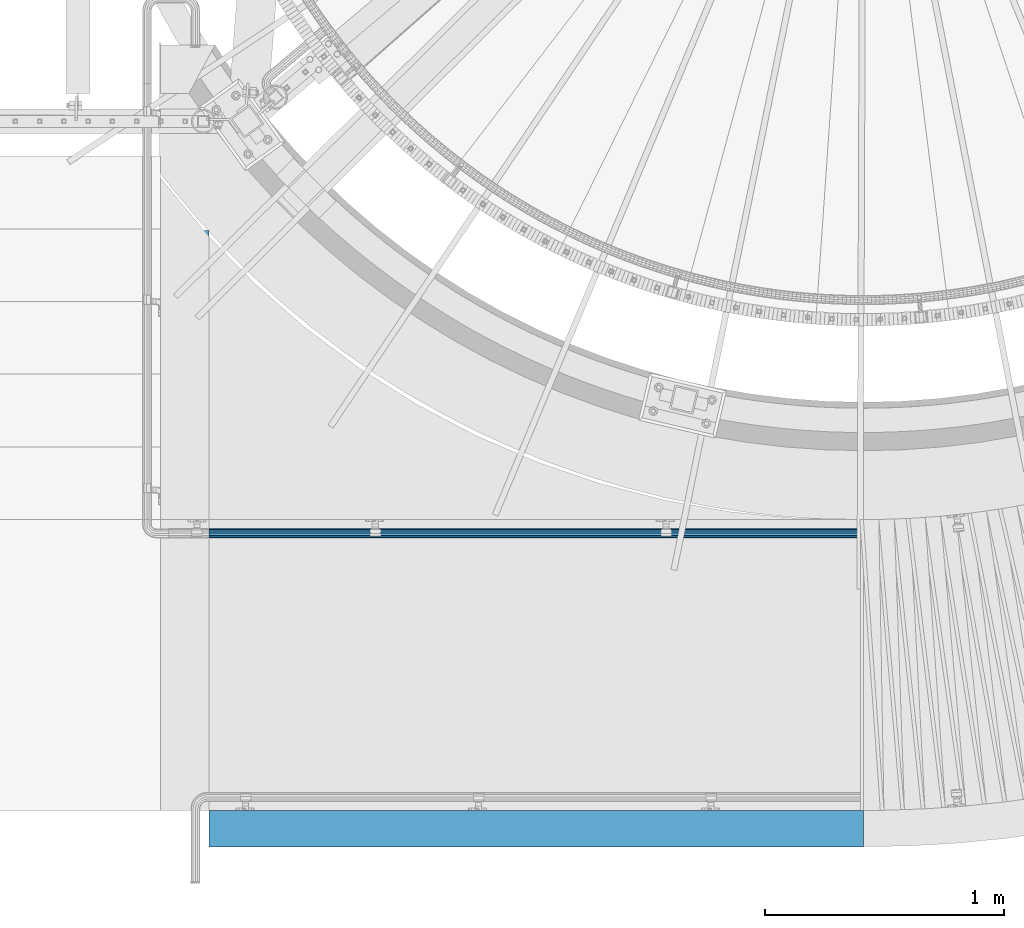
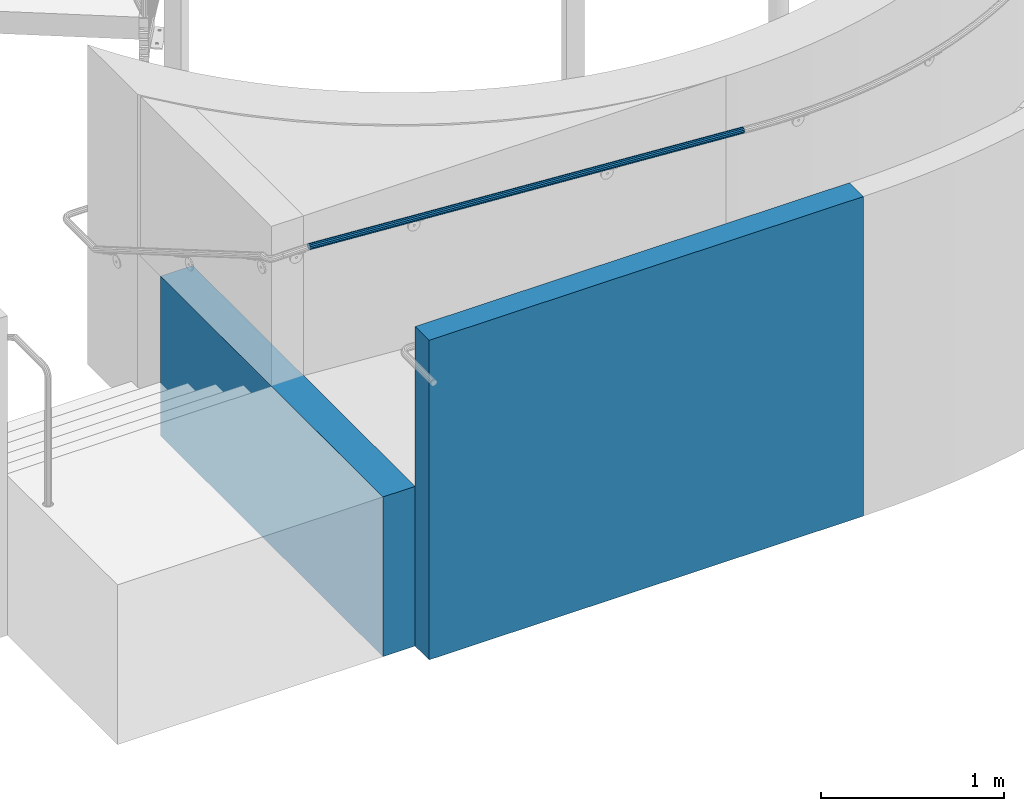
# One storey, part 335 of 975: 3 beams.
"""IFC2X3 building model written with IfcOpenShell, lengths in millimetres."""

from ifc_helpers import new_model, si_unit, frame, origin_with_axes, place, context, subcontext, project, spatial, faceted_brep, material, type_object, element, save


model = new_model("IFC2X3")

# Units and contexts
model_context = context("Model", 3, precision=1e-05, world=origin_with_axes())
body_context = subcontext(model_context, "Body", "Model", "MODEL_VIEW")
ifc_project = project(units=[si_unit("LENGTHUNIT", "METRE", prefix="MILLI"), si_unit("AREAUNIT", "SQUARE_METRE"), si_unit("VOLUMEUNIT", "CUBIC_METRE"), si_unit("MASSUNIT", "GRAM", prefix="KILO"), si_unit("TIMEUNIT", "SECOND"), si_unit("PLANEANGLEUNIT", "RADIAN"), si_unit("SOLIDANGLEUNIT", "STERADIAN"), si_unit("THERMODYNAMICTEMPERATUREUNIT", "DEGREE_CELSIUS"), si_unit("LUMINOUSINTENSITYUNIT", "LUMEN")], contexts=[model_context])

# Site, building, storey
site_placement = place(None, origin_with_axes())
site = spatial("IfcSite", under=ifc_project, at=site_placement, CompositionType="ELEMENT")
building_placement = place(site_placement, origin_with_axes())
building = spatial("IfcBuilding", under=site, at=building_placement, Name="Undefined", CompositionType="ELEMENT")
storey_placement = place(building_placement, origin_with_axes())
storey = spatial("IfcBuildingStorey", under=building, at=storey_placement, Name="Undefined", CompositionType="ELEMENT", Elevation=0.0)

# Beams
ifc_material_1 = material()
beam_type_1 = type_object("IfcBeamType", PredefinedType="NOTDEFINED")
beam_1_placement = place(storey_placement, frame((31990.0724565186, -361.949983764825, 1962.19143730185), z_axis=(0.06592640700025, 4.99999998737621e-09, 0.997824488003796), x_axis=(0.997824488003796, -1.97778945221216e-10, -0.0659264070002507)))
element("IfcBeam", 1, at=beam_1_placement, inside=storey, type_object=beam_type_1, material=ifc_material_1, Name="HANDRAIL", context=body_context, shape_type="Brep", body=[
    faceted_brep([(0.627401174744591, -15.3670000000001, 9.09494701772928e-13), (0.374349365571106, -13.3082123799555, 7.68350000000146), (2749.18278448434, -13.3082123799372, 7.68350000008013), (2749.18278448432, -15.3669999999818, 7.95807864051312e-11), (0.189102584990906, -7.68349999999992, 13.3082123799568), (2749.18278448434, -7.68349999998173, 13.3082123800355), (0.121297558256629, 1.13686837721616e-13, 15.3670000000006), (2749.18278448434, 1.8360424292041e-11, 15.3670000000793), (0.189102587526577, 7.68350000000009, 13.308212379955), (2749.18278448434, 7.68350000001828, 13.3082123800341), (0.374349369962147, 13.3082123799555, 7.68349999999828), (2749.18278448434, 13.3082123799738, 7.68350000007831), (0.627401179815934, 15.3670000000001, -1.81898940354586e-12), (2749.18278448433, 15.3670000000183, 7.68523022998124e-11), (0.88045298898578, 13.3082123799555, -7.68350000000191), (2749.18278448431, 13.3082123799737, -7.68349999992279), (1.06569976956598, 7.68350000000004, -13.3082123799572), (2749.1827844843, 7.68350000001817, -13.3082123798786), (1.1335047963039, 5.6843418860808e-14, -15.3670000000011), (2749.1827844843, 1.82467374543194e-11, -15.366999999922), (1.06569976703031, -7.68350000000004, -13.3082123799559), (2749.1827844843, -7.6834999999819, -13.3082123798777), (0.88045298459474, -13.3082123799555, -7.68349999999919), (2749.18278448431, -13.3082123799373, -7.68349999992097), (0.627401174137049, -19.05, 1.36424205265939e-12), (0.941101764859923, -16.4977839420936, -9.52499999999873), (2749.18278448431, -16.4977839420754, -9.52499999992096), (2749.18278450733, -19.0499979925621, 1.86693569048657e-07), (1.17074653647433, -9.52499999999998, -16.4977839420944), (2749.1827844843, -9.52499999998184, -16.4977839420144), (1.25480235788564, 0.0, -19.0500000000011), (2749.1827844843, 1.81898940354586e-11, -19.0499999999224), (1.17074653962118, 9.52500000000003, -16.4977839420962), (2749.1827844843, 9.52500000001822, -16.4977839420171), (0.941101770305977, 16.4977839420936, -9.52500000000191), (2749.18278448431, 16.4977839421118, -9.52499999992369), (0.627401180423476, 19.0500000000001, -1.81898940354586e-12), (2749.18278448432, 19.0500000000183, 7.6397554948926e-11), (0.313700589696964, 16.4977839420937, 9.52499999999873), (2749.18278448434, 16.4977839421119, 9.52500000007694), (0.084055818082561, 9.52500000000009, 16.4977839420931), (2749.18278448435, 9.52500000001834, 16.4977839421722), (-3.63797880709171e-12, 3.63797880709171e-12, 19.0500000000002), (2749.18278448435, 1.8360424292041e-11, 19.0500000000793), (0.0840558149393473, -9.52499999999998, 16.4977839420949), (2749.18278448435, -9.52499999998173, 16.4977839421736), (0.313700584254548, -16.4977839420936, 9.52500000000146), (2749.18278448434, -16.4977839420754, 9.52500000008058)], [[[0, 1, 2, 3]], [[1, 4, 5, 2]], [[4, 6, 7, 5]], [[6, 8, 9, 7]], [[8, 10, 11, 9]], [[10, 12, 13, 11]], [[12, 14, 15, 13]], [[14, 16, 17, 15]], [[16, 18, 19, 17]], [[18, 20, 21, 19]], [[20, 22, 23, 21]], [[22, 0, 3, 23]], [[24, 25, 26, 27]], [[25, 28, 29, 26]], [[28, 30, 31, 29]], [[30, 32, 33, 31]], [[32, 34, 35, 33]], [[34, 36, 37, 35]], [[36, 38, 39, 37]], [[38, 40, 41, 39]], [[40, 42, 43, 41]], [[42, 44, 45, 43]], [[44, 46, 47, 45]], [[46, 24, 27, 47]], [[29, 31, 33, 35, 37, 39, 41, 43, 45, 47, 27, 26], [5, 7, 9, 11, 13, 15, 17, 19, 21, 23, 3, 2]], [[46, 44, 42, 40, 38, 36, 34, 32, 30, 28, 25, 24], [22, 20, 18, 16, 14, 12, 10, 8, 6, 4, 1, 0]]]),
])
ifc_material_2 = material(Name="CONCRETE/5000")
beam_type_2 = type_object("IfcBeamType", PredefinedType="NOTDEFINED")
beam_2_placement = place(storey_placement, frame((31889.6999669118, 908.187380758472, 533.4), z_axis=(0.0, 0.0, 1.0), x_axis=(0.0, -1.0, 0.0)))
element("IfcBeam", 2, at=beam_2_placement, inside=storey, type_object=beam_type_2, material=ifc_material_2, Name="WALL", context=body_context, shape_type="Brep", body=[
    faceted_brep([(-2.1600499167107e-12, 101.599999999999, -533.4), (-2.1600499167107e-12, 101.599999999999, 533.4), (2432.187363829, 101.599999997838, 533.4), (2432.187363829, 101.599999997838, -533.4), (2.04636307898909e-12, -101.599999999999, 533.4), (2432.187363829, -101.60000000216, 533.4), (2.04636307898909e-12, -101.599999999999, -533.4), (2432.187363829, -101.60000000216, -533.4)], [[[0, 1, 2, 3]], [[1, 4, 5, 2]], [[4, 6, 7, 5]], [[6, 0, 3, 7]], [[5, 7, 3, 2]], [[6, 4, 1, 0]]]),
])
beam_type_3 = type_object("IfcBeamType", PredefinedType="NOTDEFINED")
beam_3_placement = place(storey_placement, frame((31991.2999649509, -1600.19991574892, 1066.8), z_axis=(0.0, 0.0, 1.0), x_axis=(1.0, 0.0, 0.0)))
element("IfcBeam", 3, at=beam_3_placement, inside=storey, type_object=beam_type_3, material=ifc_material_2, Name="WALL", context=body_context, shape_type="Brep", body=[
    faceted_brep([(-7.27595761418343e-12, 76.2000000000007, -1066.8), (-7.27595761418343e-12, 76.2000000000007, 1066.8), (2743.19981491537, 76.2000000001592, 1066.8), (2743.19981491537, 76.2000000001592, -1066.8), (7.04858393874019e-12, -76.2000000000007, 1066.8), (2743.19981491521, -76.1999999998407, 1066.8), (7.04858393874019e-12, -76.2000000000007, -1066.8), (2743.19981491521, -76.1999999998407, -1066.8)], [[[0, 1, 2, 3]], [[1, 4, 5, 2]], [[4, 6, 7, 5]], [[6, 0, 3, 7]], [[5, 7, 3, 2]], [[6, 4, 1, 0]]]),
])

save(model, "model.ifc")
